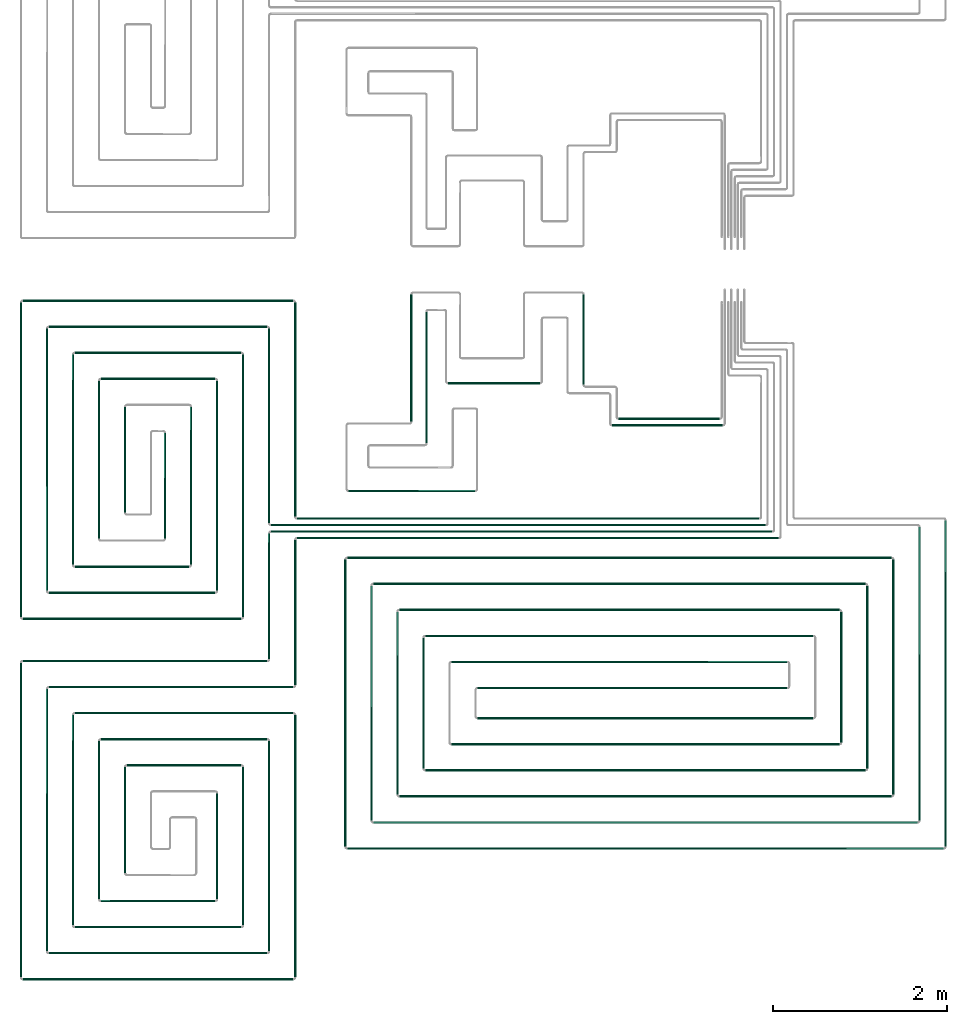
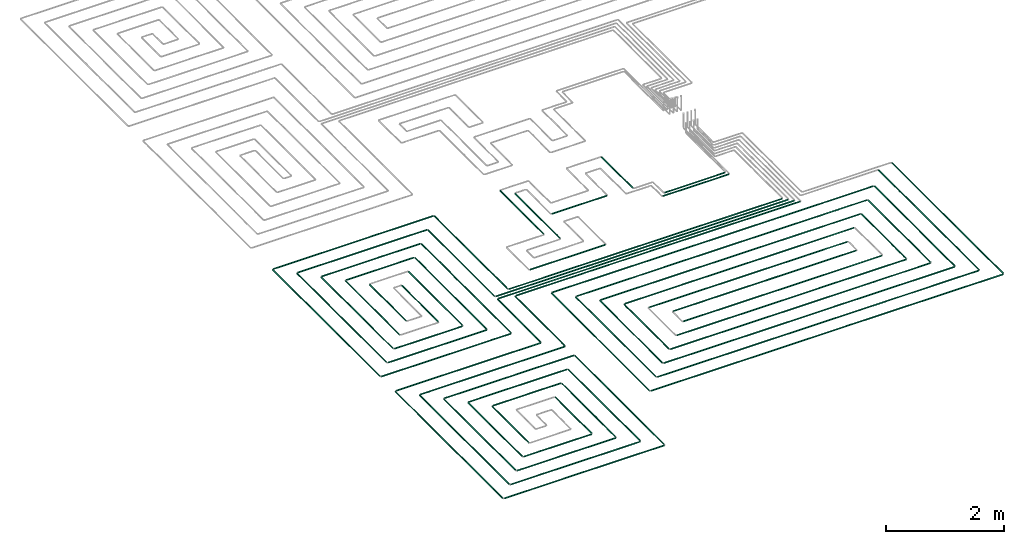
# One storey, part 1 of 12: 70 flow segments.
"""IFC2X3 building model written with IfcOpenShell, lengths in millimetres."""

from ifc_helpers import new_model, entity, si_unit, converted_unit, derived_unit, direction, frame, frame_2d, origin, origin_2d_with_axis, place, context, subcontext, project, spatial, circle, extrude, type_object, element, save


model = new_model("IFC2X3")

# Units and contexts
model_context = context("Model", 3, precision=0.01, world=origin(), true_north=direction((6.12303176911189e-17, 1.0)))
body_context = subcontext(model_context, "Body", "Model", "MODEL_VIEW")
ifc_project = project(units=[si_unit("LENGTHUNIT", "METRE", prefix="MILLI"), si_unit("AREAUNIT", "SQUARE_METRE"), si_unit("VOLUMEUNIT", "CUBIC_METRE"), converted_unit("PLANEANGLEUNIT", "DEGREE", entity("IfcRatioMeasure", 0.0174532925199433), si_unit("PLANEANGLEUNIT", "RADIAN"), dimensions=[0, 0, 0, 0, 0, 0, 0]), si_unit("MASSUNIT", "GRAM", prefix="KILO"), derived_unit("MASSDENSITYUNIT", [(si_unit("MASSUNIT", "GRAM", prefix="KILO"), 1), (si_unit("LENGTHUNIT", "METRE"), -3)]), si_unit("TIMEUNIT", "SECOND"), si_unit("FREQUENCYUNIT", "HERTZ"), si_unit("THERMODYNAMICTEMPERATUREUNIT", "DEGREE_CELSIUS"), derived_unit("THERMALTRANSMITTANCEUNIT", [(si_unit("MASSUNIT", "GRAM", prefix="KILO"), 1), (si_unit("THERMODYNAMICTEMPERATUREUNIT", "KELVIN"), -1), (si_unit("TIMEUNIT", "SECOND"), -3)]), derived_unit("VOLUMETRICFLOWRATEUNIT", [(si_unit("LENGTHUNIT", "METRE"), 3), (si_unit("TIMEUNIT", "SECOND"), -1)]), si_unit("ELECTRICCURRENTUNIT", "AMPERE"), si_unit("ELECTRICVOLTAGEUNIT", "VOLT"), si_unit("POWERUNIT", "WATT"), si_unit("FORCEUNIT", "NEWTON", prefix="KILO"), si_unit("ILLUMINANCEUNIT", "LUX"), si_unit("LUMINOUSFLUXUNIT", "LUMEN"), si_unit("LUMINOUSINTENSITYUNIT", "CANDELA"), derived_unit("USERDEFINED", [(si_unit("MASSUNIT", "GRAM", prefix="KILO"), -1), (si_unit("LENGTHUNIT", "METRE"), -2), (si_unit("TIMEUNIT", "SECOND"), 3), (si_unit("LUMINOUSFLUXUNIT", "LUMEN"), 1)]), derived_unit("LINEARVELOCITYUNIT", [(si_unit("LENGTHUNIT", "METRE"), 1), (si_unit("TIMEUNIT", "SECOND"), -1)]), si_unit("PRESSUREUNIT", "PASCAL"), derived_unit("USERDEFINED", [(si_unit("LENGTHUNIT", "METRE"), -2), (si_unit("MASSUNIT", "GRAM", prefix="KILO"), 1), (si_unit("TIMEUNIT", "SECOND"), -2)])], contexts=[model_context])

# Site, building, storey
site_placement = place(None, origin())
site = spatial("IfcSite", under=ifc_project, at=site_placement, CompositionType="ELEMENT")
building_placement = place(site_placement, origin())
building = spatial("IfcBuilding", under=site, at=building_placement, CompositionType="ELEMENT")
storey_placement = place(building_placement, frame((0.0, 0.0, 4000.0)))
storey = spatial("IfcBuildingStorey", under=building, at=storey_placement, Name="01 Level", CompositionType="ELEMENT", Elevation=4000.0)

# Flow segments
pipe_segment_type = type_object("IfcPipeSegmentType", PredefinedType="NOTDEFINED")
flow_segment_1_placement = place(storey_placement, frame((20884.4386293741, -71711.6450070283, -81.5952722359175)))
element("IfcFlowSegment", 1, at=flow_segment_1_placement, inside=storey, type_object=pipe_segment_type, context=body_context, shape_type="SweptSolid", body=[
    extrude(circle(Radius=10.0, at=frame_2d((-8.66293703438714e-12, 0.0), x_axis=(1.0, 0.0))), frame((0.0, 11.5952722359136, 11.5952722359158), z_axis=(1.0, 0.0, 0.0), x_axis=(0.0, 1.0, 0.0)), (0.0, 0.0, 1.0), 5324.24692007345),
])
flow_segment_2_placement = place(storey_placement, frame((20584.4386293741, -71786.6450070283, -81.5952722359161)))
element("IfcFlowSegment", 2, at=flow_segment_2_placement, inside=storey, type_object=pipe_segment_type, context=body_context, shape_type="SweptSolid", body=[
    extrude(circle(Radius=10.0, at=frame_2d((-8.66293703438714e-12, 0.0), x_axis=(1.0, 0.0))), frame((0.0, 11.5952722359223, 11.5952722359158), z_axis=(1.0, 0.0, 0.0), x_axis=(0.0, 1.0, 0.0)), (0.0, 0.0, 1.0), 5699.24692007345),
])
flow_segment_3_placement = place(storey_placement, frame((20584.4386293741, -71861.6450070283, -81.5952722359161)))
element("IfcFlowSegment", 3, at=flow_segment_3_placement, inside=storey, type_object=pipe_segment_type, context=body_context, shape_type="SweptSolid", body=[
    extrude(circle(Radius=10.0, at=frame_2d((-2.59888111031614e-11, 0.0), x_axis=(1.0, 0.0))), frame((0.0, 11.5952722359396, 11.5952722359158), z_axis=(1.0, 0.0, 0.0), x_axis=(0.0, 1.0, 0.0)), (0.0, 0.0, 1.0), 5774.24692007345),
])
flow_segment_4_placement = place(storey_placement, frame((20884.4386293741, -71936.6450070283, -81.5952722359161)))
element("IfcFlowSegment", 4, at=flow_segment_4_placement, inside=storey, type_object=pipe_segment_type, context=body_context, shape_type="SweptSolid", body=[
    extrude(circle(Radius=10.0, at=frame_2d((-1.73258740687743e-11, 0.0), x_axis=(1.0, 0.0))), frame((0.0, 11.595272235931, 11.5952722359158), z_axis=(1.0, 0.0, 0.0), x_axis=(0.0, 1.0, 0.0)), (0.0, 0.0, 1.0), 5549.24692007344),
])
flow_segment_5_placement = place(storey_placement, frame((20552.8433571382, -73321.2395851399, -81.5952722359189)))
element("IfcFlowSegment", 5, at=flow_segment_5_placement, inside=storey, type_object=pipe_segment_type, context=body_context, shape_type="SweptSolid", body=[
    extrude(circle(Radius=10.0, at=origin_2d_with_axis()), frame((11.595272235918, 0.0, 11.5952722359158), z_axis=(0.0, 1.0, 0.0), x_axis=(-1.0, 0.0, 0.0)), (0.0, 0.0, 1.0), 1451.18985034759),
])
flow_segment_6_placement = place(storey_placement, frame((20852.8433571382, -73621.2395851399, -81.5952722359189)))
element("IfcFlowSegment", 6, at=flow_segment_6_placement, inside=storey, type_object=pipe_segment_type, context=body_context, shape_type="SweptSolid", body=[
    extrude(circle(Radius=10.0, at=origin_2d_with_axis()), frame((11.5952722359223, 0.0, 11.5952722359158), z_axis=(0.0, 1.0, 0.0), x_axis=(-1.0, 0.0, 0.0)), (0.0, 0.0, 1.0), 1676.18985034759),
])
flow_segment_7_placement = place(storey_placement, frame((24586.730888343, -70562.9096240978, -81.5952722359261)))
element("IfcFlowSegment", 7, at=flow_segment_7_placement, inside=storey, type_object=pipe_segment_type, context=body_context, shape_type="SweptSolid", body=[
    extrude(circle(Radius=10.0, at=origin_2d_with_axis()), frame((0.0, 11.5952722359136, 11.5952722359158), z_axis=(1.0, 0.0, 0.0), x_axis=(0.0, -1.0, 0.0)), (0.0, 0.0, 1.0), 1169.30608362779),
])
flow_segment_8_placement = place(storey_placement, frame((20852.8433571382, -71680.0497347924, -81.5952722359189)))
element("IfcFlowSegment", 8, at=flow_segment_8_placement, inside=storey, type_object=pipe_segment_type, context=body_context, shape_type="SweptSolid", body=[
    extrude(circle(Radius=10.0, at=frame_2d((-2.16573425859679e-11, 0.0), x_axis=(1.0, 0.0))), frame((11.5952722359396, 0.0, 11.5952722359158), z_axis=(0.0, 1.0, 0.0), x_axis=(-1.0, 0.0, 0.0)), (0.0, 0.0, 1.0), 2468.81014965244),
])
flow_segment_9_placement = place(storey_placement, frame((20552.8433571382, -71755.0497347924, -81.5952722359189)))
element("IfcFlowSegment", 9, at=flow_segment_9_placement, inside=storey, type_object=pipe_segment_type, context=body_context, shape_type="SweptSolid", body=[
    extrude(circle(Radius=10.0, at=origin_2d_with_axis()), frame((11.5952722359223, 0.0, 11.5952722359158), z_axis=(0.0, 1.0, 0.0), x_axis=(1.0, 0.0, 0.0)), (0.0, 0.0, 1.0), 2243.81014965244),
])
flow_segment_10_placement = place(storey_placement, frame((17725.6253473195, -69202.8348573759, -81.5952722359189)))
element("IfcFlowSegment", 10, at=flow_segment_10_placement, inside=storey, type_object=pipe_segment_type, context=body_context, shape_type="SweptSolid", body=[
    extrude(circle(Radius=10.0, at=frame_2d((-1.73258740687743e-11, 0.0), x_axis=(1.0, 0.0))), frame((0.0, 11.595272235931, 11.5952722359158), z_axis=(1.0, 0.0, 0.0), x_axis=(0.0, 1.0, 0.0)), (0.0, 0.0, 1.0), 3118.81328205467),
])
flow_segment_11_placement = place(storey_placement, frame((18025.6253473195, -69502.8348573758, -81.5952722359189)))
element("IfcFlowSegment", 11, at=flow_segment_11_placement, inside=storey, type_object=pipe_segment_type, context=body_context, shape_type="SweptSolid", body=[
    extrude(circle(Radius=10.0, at=frame_2d((-1.73258740687743e-11, 0.0), x_axis=(1.0, 0.0))), frame((0.0, 11.595272235931, 11.5952722359158), z_axis=(1.0, 0.0, 0.0), x_axis=(0.0, 1.0, 0.0)), (0.0, 0.0, 1.0), 2518.81328205467),
])
flow_segment_12_placement = place(storey_placement, frame((17994.0300750835, -72534.5978364231, -81.5952722359202)))
element("IfcFlowSegment", 12, at=flow_segment_12_placement, inside=storey, type_object=pipe_segment_type, context=body_context, shape_type="SweptSolid", body=[
    extrude(circle(Radius=10.0, at=frame_2d((-2.38230768445646e-11, 0.0), x_axis=(1.0, 0.0))), frame((11.5952722359396, 0.0, 11.5952722359158), z_axis=(0.0, 1.0, 0.0), x_axis=(-1.0, 0.0, 0.0)), (0.0, 0.0, 1.0), 3023.35825128324),
])
flow_segment_13_placement = place(storey_placement, frame((17694.0300750835, -72834.5978364231, -81.5952722359202)))
element("IfcFlowSegment", 13, at=flow_segment_13_placement, inside=storey, type_object=pipe_segment_type, context=body_context, shape_type="SweptSolid", body=[
    extrude(circle(Radius=10.0, at=frame_2d((-2.16573425859679e-11, 0.0), x_axis=(1.0, 0.0))), frame((11.5952722359374, 0.0, 11.5952722359158), z_axis=(0.0, 1.0, 0.0), x_axis=(-1.0, 0.0, 0.0)), (0.0, 0.0, 1.0), 3623.35825128323),
])
flow_segment_14_placement = place(storey_placement, frame((18025.6253473194, -72566.1931086591, -81.5952722359189)))
element("IfcFlowSegment", 14, at=flow_segment_14_placement, inside=storey, type_object=pipe_segment_type, context=body_context, shape_type="SweptSolid", body=[
    extrude(circle(Radius=10.0, at=frame_2d((-8.66293703438714e-12, 0.0), x_axis=(1.0, 0.0))), frame((0.0, 11.5952722359223, 11.5952722359158), z_axis=(1.0, 0.0, 0.0), x_axis=(0.0, 1.0, 0.0)), (0.0, 0.0, 1.0), 1918.81328205468),
])
flow_segment_15_placement = place(storey_placement, frame((17725.6253473194, -72866.1931086591, -81.5952722359175)))
element("IfcFlowSegment", 15, at=flow_segment_15_placement, inside=storey, type_object=pipe_segment_type, context=body_context, shape_type="SweptSolid", body=[
    extrude(circle(Radius=10.0, at=frame_2d((-8.66293703438714e-12, 0.0), x_axis=(1.0, 0.0))), frame((0.0, 11.595272235931, 11.5952722359158), z_axis=(1.0, 0.0, 0.0), x_axis=(0.0, 1.0, 0.0)), (0.0, 0.0, 1.0), 2518.81328205467),
])
flow_segment_16_placement = place(storey_placement, frame((20252.8433571382, -72834.5978364231, -81.595272235922)))
element("IfcFlowSegment", 16, at=flow_segment_16_placement, inside=storey, type_object=pipe_segment_type, context=body_context, shape_type="SweptSolid", body=[
    extrude(circle(Radius=10.0, at=frame_2d((-2.59888111031614e-11, 0.0), x_axis=(1.0, 0.0))), frame((11.5952722359396, 0.0, 11.5952722359158), z_axis=(0.0, 1.0, 0.0), x_axis=(-1.0, 0.0, 0.0)), (0.0, 0.0, 1.0), 3023.35825128323),
])
flow_segment_17_placement = place(storey_placement, frame((19952.8433571382, -72534.5978364231, -81.5952722359189)))
element("IfcFlowSegment", 17, at=flow_segment_17_placement, inside=storey, type_object=pipe_segment_type, context=body_context, shape_type="SweptSolid", body=[
    extrude(circle(Radius=10.0, at=origin_2d_with_axis()), frame((11.5952722359223, 0.0, 11.5952722359158), z_axis=(0.0, 1.0, 0.0), x_axis=(1.0, 0.0, 0.0)), (0.0, 0.0, 1.0), 2423.35825128325),
])
flow_segment_18_placement = place(storey_placement, frame((18325.6253473194, -69802.8348573758, -81.595272235922)))
element("IfcFlowSegment", 18, at=flow_segment_18_placement, inside=storey, type_object=pipe_segment_type, context=body_context, shape_type="SweptSolid", body=[
    extrude(circle(Radius=10.0, at=origin_2d_with_axis()), frame((0.0, 11.5952722359396, 11.5952722359158), z_axis=(1.0, 0.0, 0.0), x_axis=(0.0, -1.0, 0.0)), (0.0, 0.0, 1.0), 1918.8132820547),
])
flow_segment_19_placement = place(storey_placement, frame((18625.6253473194, -70102.8348573758, -81.5952722359202)))
element("IfcFlowSegment", 19, at=flow_segment_19_placement, inside=storey, type_object=pipe_segment_type, context=body_context, shape_type="SweptSolid", body=[
    extrude(circle(Radius=10.0, at=frame_2d((-8.66293703438714e-12, 0.0), x_axis=(1.0, 0.0))), frame((0.0, 11.5952722359223, 11.5952722359158), z_axis=(1.0, 0.0, 0.0), x_axis=(0.0, 1.0, 0.0)), (0.0, 0.0, 1.0), 1318.8132820547),
])
flow_segment_20_placement = place(storey_placement, frame((18594.0300750835, -71934.5978364232, -81.595272235922)))
element("IfcFlowSegment", 20, at=flow_segment_20_placement, inside=storey, type_object=pipe_segment_type, context=body_context, shape_type="SweptSolid", body=[
    extrude(circle(Radius=10.0, at=frame_2d((-1.94916083273711e-11, 0.0), x_axis=(1.0, 0.0))), frame((11.5952722359353, 0.0, 11.5952722359158), z_axis=(0.0, 1.0, 0.0), x_axis=(-1.0, 0.0, 0.0)), (0.0, 0.0, 1.0), 1823.35825128327),
])
flow_segment_21_placement = place(storey_placement, frame((18294.0300750835, -72234.5978364231, -81.595272235922)))
element("IfcFlowSegment", 21, at=flow_segment_21_placement, inside=storey, type_object=pipe_segment_type, context=body_context, shape_type="SweptSolid", body=[
    extrude(circle(Radius=10.0, at=frame_2d((-1.94916083273711e-11, 0.0), x_axis=(1.0, 0.0))), frame((11.5952722359353, 0.0, 11.5952722359158), z_axis=(0.0, 1.0, 0.0), x_axis=(-1.0, 0.0, 0.0)), (0.0, 0.0, 1.0), 2423.35825128326),
])
flow_segment_22_placement = place(storey_placement, frame((18325.6253473194, -72266.1931086591, -81.595272235922)))
element("IfcFlowSegment", 22, at=flow_segment_22_placement, inside=storey, type_object=pipe_segment_type, context=body_context, shape_type="SweptSolid", body=[
    extrude(circle(Radius=10.0, at=frame_2d((-8.66293703438714e-12, 0.0), x_axis=(1.0, 0.0))), frame((0.0, 11.5952722359223, 11.5952722359158), z_axis=(1.0, 0.0, 0.0), x_axis=(0.0, 1.0, 0.0)), (0.0, 0.0, 1.0), 1318.81328205471),
])
flow_segment_23_placement = place(storey_placement, frame((19652.8433571382, -72234.5978364232, -81.5952722359234)))
element("IfcFlowSegment", 23, at=flow_segment_23_placement, inside=storey, type_object=pipe_segment_type, context=body_context, shape_type="SweptSolid", body=[
    extrude(circle(Radius=10.0, at=frame_2d((-1.29944055515807e-11, 0.0), x_axis=(1.0, 0.0))), frame((11.595272235931, 0.0, 11.5952722359158), z_axis=(0.0, 1.0, 0.0), x_axis=(-1.0, 0.0, 0.0)), (0.0, 0.0, 1.0), 1823.35825128327),
])
flow_segment_24_placement = place(storey_placement, frame((19352.8433571382, -71934.5978364232, -81.5952722359229)))
element("IfcFlowSegment", 24, at=flow_segment_24_placement, inside=storey, type_object=pipe_segment_type, context=body_context, shape_type="SweptSolid", body=[
    extrude(circle(Radius=10.0, at=frame_2d((-8.66293703438714e-12, 0.0), x_axis=(1.0, 0.0))), frame((11.5952722359245, 0.0, 11.5952722359158), z_axis=(0.0, 1.0, 0.0), x_axis=(-1.0, 0.0, 0.0)), (0.0, 0.0, 1.0), 1223.35825128328),
])
flow_segment_25_placement = place(storey_placement, frame((18894.0300750835, -71634.5978364232, -81.5952722359239)))
element("IfcFlowSegment", 25, at=flow_segment_25_placement, inside=storey, type_object=pipe_segment_type, context=body_context, shape_type="SweptSolid", body=[
    extrude(circle(Radius=10.0, at=frame_2d((-1.51601398101775e-11, 0.0), x_axis=(1.0, 0.0))), frame((11.595272235931, 0.0, 11.5952722359158), z_axis=(0.0, 1.0, 0.0), x_axis=(-1.0, 0.0, 0.0)), (0.0, 0.0, 1.0), 1223.35825128332),
])
flow_segment_26_placement = place(storey_placement, frame((20852.8433571382, -76984.5978364232, -81.5952722359198)))
element("IfcFlowSegment", 26, at=flow_segment_26_placement, inside=storey, type_object=pipe_segment_type, context=body_context, shape_type="SweptSolid", body=[
    extrude(circle(Radius=10.0, at=frame_2d((-2.59888111031614e-11, 0.0), x_axis=(1.0, 0.0))), frame((11.5952722359353, 0.0, 11.5952722359158), z_axis=(0.0, 1.0, 0.0), x_axis=(-1.0, 0.0, 0.0)), (0.0, 0.0, 1.0), 3023.35825128325),
])
flow_segment_27_placement = place(storey_placement, frame((20552.8433571382, -76684.5978364232, -81.5952722359179)))
element("IfcFlowSegment", 27, at=flow_segment_27_placement, inside=storey, type_object=pipe_segment_type, context=body_context, shape_type="SweptSolid", body=[
    extrude(circle(Radius=10.0, at=origin_2d_with_axis()), frame((11.595272235918, 0.0, 11.5952722359158), z_axis=(0.0, 1.0, 0.0), x_axis=(1.0, 0.0, 0.0)), (0.0, 0.0, 1.0), 2423.35825128326),
])
flow_segment_28_placement = place(storey_placement, frame((17994.0300750835, -76684.5978364232, -81.595272235922)))
element("IfcFlowSegment", 28, at=flow_segment_28_placement, inside=storey, type_object=pipe_segment_type, context=body_context, shape_type="SweptSolid", body=[
    extrude(circle(Radius=10.0, at=frame_2d((-2.81545453617582e-11, 0.0), x_axis=(1.0, 0.0))), frame((11.5952722359439, 0.0, 11.5952722359158), z_axis=(0.0, 1.0, 0.0), x_axis=(-1.0, 0.0, 0.0)), (0.0, 0.0, 1.0), 3023.35825128327),
])
flow_segment_29_placement = place(storey_placement, frame((17694.0300750835, -76984.5978364231, -81.595272235922)))
element("IfcFlowSegment", 29, at=flow_segment_29_placement, inside=storey, type_object=pipe_segment_type, context=body_context, shape_type="SweptSolid", body=[
    extrude(circle(Radius=10.0, at=frame_2d((-2.81545453617582e-11, 0.0), x_axis=(1.0, 0.0))), frame((11.5952722359418, 0.0, 11.5952722359158), z_axis=(0.0, 1.0, 0.0), x_axis=(-1.0, 0.0, 0.0)), (0.0, 0.0, 1.0), 3623.35825128325),
])
flow_segment_30_placement = place(storey_placement, frame((20252.8433571382, -76384.5978364232, -81.5952722359229)))
element("IfcFlowSegment", 30, at=flow_segment_30_placement, inside=storey, type_object=pipe_segment_type, context=body_context, shape_type="SweptSolid", body=[
    extrude(circle(Radius=10.0, at=frame_2d((-2.16573425859679e-11, 0.0), x_axis=(1.0, 0.0))), frame((11.5952722359396, 0.0, 11.5952722359158), z_axis=(0.0, 1.0, 0.0), x_axis=(-1.0, 0.0, 0.0)), (0.0, 0.0, 1.0), 1823.35825128329),
])
flow_segment_31_placement = place(storey_placement, frame((19952.8433571382, -76084.5978364232, -81.5952722359202)))
element("IfcFlowSegment", 31, at=flow_segment_31_placement, inside=storey, type_object=pipe_segment_type, context=body_context, shape_type="SweptSolid", body=[
    extrude(circle(Radius=10.0, at=origin_2d_with_axis()), frame((11.595272235918, 0.0, 11.5952722359158), z_axis=(0.0, 1.0, 0.0), x_axis=(1.0, 0.0, 0.0)), (0.0, 0.0, 1.0), 1223.35825128325),
])
flow_segment_32_placement = place(storey_placement, frame((18594.0300750835, -76084.5978364232, -81.5952722359284)))
element("IfcFlowSegment", 32, at=flow_segment_32_placement, inside=storey, type_object=pipe_segment_type, context=body_context, shape_type="SweptSolid", body=[
    extrude(circle(Radius=10.0, at=origin_2d_with_axis()), frame((11.5952722359158, 0.0, 11.5952722359158), z_axis=(0.0, 1.0, 0.0), x_axis=(1.0, 0.0, 0.0)), (0.0, 0.0, 1.0), 1823.35825128331),
])
flow_segment_33_placement = place(storey_placement, frame((18294.0300750835, -76384.5978364232, -81.5952722359261)))
element("IfcFlowSegment", 33, at=flow_segment_33_placement, inside=storey, type_object=pipe_segment_type, context=body_context, shape_type="SweptSolid", body=[
    extrude(circle(Radius=10.0, at=origin_2d_with_axis()), frame((11.5952722359158, 0.0, 11.5952722359158), z_axis=(0.0, 1.0, 0.0), x_axis=(1.0, 0.0, 0.0)), (0.0, 0.0, 1.0), 2423.35825128329),
])
flow_segment_34_placement = place(storey_placement, frame((18894.0300750835, -75784.5978364232, -81.5952722359257)))
element("IfcFlowSegment", 34, at=flow_segment_34_placement, inside=storey, type_object=pipe_segment_type, context=body_context, shape_type="SweptSolid", body=[
    extrude(circle(Radius=10.0, at=frame_2d((-2.16573425859679e-11, 0.0), x_axis=(1.0, 0.0))), frame((11.5952722359353, 0.0, 11.5952722359158), z_axis=(0.0, 1.0, 0.0), x_axis=(-1.0, 0.0, 0.0)), (0.0, 0.0, 1.0), 1223.35825128335),
])
for number, where in (
    (35, (17725.6253473195, -73352.8348573759, -81.5952722359175)),
    (36, (18025.6253473194, -73652.8348573759, -81.595272235917)),
):
    element("IfcFlowSegment", number, at=place(storey_placement, frame(where)), inside=storey, type_object=pipe_segment_type, context=body_context, shape_type="SweptSolid", body=[
        extrude(circle(Radius=10.0, at=frame_2d((-3.46517481375486e-11, 0.0), x_axis=(1.0, 0.0))), frame((0.0, 11.5952722359483, 11.5952722359158), z_axis=(1.0, 0.0, 0.0), x_axis=(0.0, 1.0, 0.0)), (0.0, 0.0, 1.0), 2818.81328205464),
    ])
flow_segment_35_placement = place(storey_placement, frame((18025.6253473194, -76716.1931086591, -81.5952722359179)))
element("IfcFlowSegment", 37, at=flow_segment_35_placement, inside=storey, type_object=pipe_segment_type, context=body_context, shape_type="SweptSolid", body=[
    extrude(circle(Radius=10.0, at=frame_2d((-8.66293703438714e-12, 0.0), x_axis=(1.0, 0.0))), frame((0.0, 11.5952722359136, 11.5952722359158), z_axis=(1.0, 0.0, 0.0), x_axis=(0.0, 1.0, 0.0)), (0.0, 0.0, 1.0), 2518.8132820547),
])
flow_segment_36_placement = place(storey_placement, frame((17725.6253473194, -77016.1931086591, -81.595272235917)))
element("IfcFlowSegment", 38, at=flow_segment_36_placement, inside=storey, type_object=pipe_segment_type, context=body_context, shape_type="SweptSolid", body=[
    extrude(circle(Radius=10.0, at=frame_2d((-8.66293703438714e-12, 0.0), x_axis=(1.0, 0.0))), frame((0.0, 11.595272235931, 11.5952722359158), z_axis=(1.0, 0.0, 0.0), x_axis=(0.0, 1.0, 0.0)), (0.0, 0.0, 1.0), 3118.81328205468),
])
flow_segment_37_placement = place(storey_placement, frame((18325.6253473194, -73952.8348573758, -81.5952722359198)))
element("IfcFlowSegment", 39, at=flow_segment_37_placement, inside=storey, type_object=pipe_segment_type, context=body_context, shape_type="SweptSolid", body=[
    extrude(circle(Radius=10.0, at=frame_2d((-1.73258740687743e-11, 0.0), x_axis=(1.0, 0.0))), frame((0.0, 11.595272235931, 11.5952722359158), z_axis=(1.0, 0.0, 0.0), x_axis=(0.0, 1.0, 0.0)), (0.0, 0.0, 1.0), 2518.8132820547),
])
flow_segment_38_placement = place(storey_placement, frame((18625.6253473194, -74252.8348573758, -81.5952722359202)))
element("IfcFlowSegment", 40, at=flow_segment_38_placement, inside=storey, type_object=pipe_segment_type, context=body_context, shape_type="SweptSolid", body=[
    extrude(circle(Radius=10.0, at=frame_2d((-1.73258740687743e-11, 0.0), x_axis=(1.0, 0.0))), frame((0.0, 11.595272235931, 11.5952722359158), z_axis=(1.0, 0.0, 0.0), x_axis=(0.0, 1.0, 0.0)), (0.0, 0.0, 1.0), 1918.8132820547),
])
flow_segment_39_placement = place(storey_placement, frame((18625.6253473194, -76116.1931086591, -81.5952722359202)))
element("IfcFlowSegment", 41, at=flow_segment_39_placement, inside=storey, type_object=pipe_segment_type, context=body_context, shape_type="SweptSolid", body=[
    extrude(circle(Radius=10.0, at=origin_2d_with_axis()), frame((0.0, 11.5952722359136, 11.5952722359158), z_axis=(1.0, 0.0, 0.0), x_axis=(0.0, 1.0, 0.0)), (0.0, 0.0, 1.0), 1318.81328205473),
])
flow_segment_40_placement = place(storey_placement, frame((18325.6253473194, -76416.1931086591, -81.5952722359198)))
element("IfcFlowSegment", 42, at=flow_segment_40_placement, inside=storey, type_object=pipe_segment_type, context=body_context, shape_type="SweptSolid", body=[
    extrude(circle(Radius=10.0, at=frame_2d((-8.66293703438714e-12, 0.0), x_axis=(1.0, 0.0))), frame((0.0, 11.5952722359223, 11.5952722359158), z_axis=(1.0, 0.0, 0.0), x_axis=(0.0, 1.0, 0.0)), (0.0, 0.0, 1.0), 1918.81328205471),
])
flow_segment_41_placement = place(storey_placement, frame((18925.6253473194, -74552.8348573758, -81.5952722359229)))
element("IfcFlowSegment", 43, at=flow_segment_41_placement, inside=storey, type_object=pipe_segment_type, context=body_context, shape_type="SweptSolid", body=[
    extrude(circle(Radius=10.0, at=frame_2d((-8.66293703438714e-12, 0.0), x_axis=(1.0, 0.0))), frame((0.0, 11.5952722359223, 11.5952722359158), z_axis=(1.0, 0.0, 0.0), x_axis=(0.0, 1.0, 0.0)), (0.0, 0.0, 1.0), 1318.81328205473),
])
flow_segment_42_placement = place(storey_placement, frame((28341.5018091839, -75479.8436457932, -81.5952722359161)))
element("IfcFlowSegment", 44, at=flow_segment_42_placement, inside=storey, type_object=pipe_segment_type, context=body_context, shape_type="SweptSolid", body=[
    extrude(circle(Radius=10.0, at=origin_2d_with_axis()), frame((11.595272235918, 0.0, 11.5952722359158), z_axis=(0.0, 1.0, 0.0), x_axis=(1.0, 0.0, 0.0)), (0.0, 0.0, 1.0), 3759.79391100087),
])
flow_segment_43_placement = place(storey_placement, frame((28041.5018091839, -75179.8436457933, -81.5952722359193)))
element("IfcFlowSegment", 45, at=flow_segment_43_placement, inside=storey, type_object=pipe_segment_type, context=body_context, shape_type="SweptSolid", body=[
    extrude(circle(Radius=10.0, at=frame_2d((-2.59888111031614e-11, 0.0), x_axis=(1.0, 0.0))), frame((11.5952722359526, 0.0, 11.5952722359158), z_axis=(0.0, 1.0, 0.0), x_axis=(-1.0, 0.0, 0.0)), (0.0, 0.0, 1.0), 3384.79391100087),
])
flow_segment_44_placement = place(storey_placement, frame((27741.5018091839, -74879.8436457933, -81.5952722359175)))
element("IfcFlowSegment", 46, at=flow_segment_44_placement, inside=storey, type_object=pipe_segment_type, context=body_context, shape_type="SweptSolid", body=[
    extrude(circle(Radius=10.0, at=origin_2d_with_axis()), frame((11.5952722359223, 0.0, 11.5952722359158), z_axis=(0.0, 1.0, 0.0), x_axis=(1.0, 0.0, 0.0)), (0.0, 0.0, 1.0), 2707.85893213088),
])
flow_segment_45_placement = place(storey_placement, frame((27441.5018091839, -74579.8436457933, -81.5952722359166)))
element("IfcFlowSegment", 47, at=flow_segment_45_placement, inside=storey, type_object=pipe_segment_type, context=body_context, shape_type="SweptSolid", body=[
    extrude(circle(Radius=10.0, at=frame_2d((-2.16573425859679e-11, 0.0), x_axis=(1.0, 0.0))), frame((11.5952722359396, 0.0, 11.5952722359158), z_axis=(0.0, 1.0, 0.0), x_axis=(-1.0, 0.0, 0.0)), (0.0, 0.0, 1.0), 2107.85893213088),
])
flow_segment_46_placement = place(storey_placement, frame((21730.6562350407, -75179.8436457932, -81.5952722359266)))
element("IfcFlowSegment", 48, at=flow_segment_46_placement, inside=storey, type_object=pipe_segment_type, context=body_context, shape_type="SweptSolid", body=[
    extrude(circle(Radius=10.0, at=frame_2d((-3.46517481375486e-11, 0.0), x_axis=(1.0, 0.0))), frame((11.5952722359526, 0.0, 11.5952722359158), z_axis=(0.0, 1.0, 0.0), x_axis=(-1.0, 0.0, 0.0)), (0.0, 0.0, 1.0), 2707.85893213097),
])
flow_segment_47_placement = place(storey_placement, frame((21430.6562350407, -75479.8436457932, -81.595272235928)))
element("IfcFlowSegment", 49, at=flow_segment_47_placement, inside=storey, type_object=pipe_segment_type, context=body_context, shape_type="SweptSolid", body=[
    extrude(circle(Radius=10.0, at=frame_2d((-2.59888111031614e-11, 0.0), x_axis=(1.0, 0.0))), frame((11.5952722359483, 0.0, 11.5952722359158), z_axis=(0.0, 1.0, 0.0), x_axis=(-1.0, 0.0, 0.0)), (0.0, 0.0, 1.0), 3307.85893213096),
])
flow_segment_48_placement = place(storey_placement, frame((22330.6562350407, -74579.8436457932, -81.595272235932)))
element("IfcFlowSegment", 50, at=flow_segment_48_placement, inside=storey, type_object=pipe_segment_type, context=body_context, shape_type="SweptSolid", body=[
    extrude(circle(Radius=10.0, at=frame_2d((-2.59888111031614e-11, 0.0), x_axis=(1.0, 0.0))), frame((11.5952722359353, 0.0, 11.5952722359158), z_axis=(0.0, 1.0, 0.0), x_axis=(-1.0, 0.0, 0.0)), (0.0, 0.0, 1.0), 1507.858932131),
])
flow_segment_49_placement = place(storey_placement, frame((22030.6562350407, -74879.8436457932, -81.595272235933)))
element("IfcFlowSegment", 51, at=flow_segment_49_placement, inside=storey, type_object=pipe_segment_type, context=body_context, shape_type="SweptSolid", body=[
    extrude(circle(Radius=10.0, at=frame_2d((-2.16573425859679e-11, 0.0), x_axis=(1.0, 0.0))), frame((11.5952722359396, 0.0, 11.5952722359158), z_axis=(0.0, 1.0, 0.0), x_axis=(-1.0, 0.0, 0.0)), (0.0, 0.0, 1.0), 2107.85893213099),
])
flow_segment_50_placement = place(storey_placement, frame((21762.2515072766, -75211.4389180292, -81.5952722359275)))
element("IfcFlowSegment", 52, at=flow_segment_50_placement, inside=storey, type_object=pipe_segment_type, context=body_context, shape_type="SweptSolid", body=[
    extrude(circle(Radius=10.0, at=origin_2d_with_axis()), frame((0.0, 11.5952722359483, 11.5952722359158), z_axis=(1.0, 0.0, 0.0), x_axis=(0.0, -1.0, 0.0)), (0.0, 0.0, 1.0), 6270.84557414324),
])
flow_segment_51_placement = place(storey_placement, frame((21462.2515072766, -75511.4389180292, -81.5952722359161)))
element("IfcFlowSegment", 53, at=flow_segment_51_placement, inside=storey, type_object=pipe_segment_type, context=body_context, shape_type="SweptSolid", body=[
    extrude(circle(Radius=10.0, at=frame_2d((-2.59888111031614e-11, 0.0), x_axis=(1.0, 0.0))), frame((0.0, 11.5952722359396, 11.5952722359158), z_axis=(1.0, 0.0, 0.0), x_axis=(0.0, 1.0, 0.0)), (0.0, 0.0, 1.0), 6870.84557414322),
])
flow_segment_52_placement = place(storey_placement, frame((22362.2515072766, -74611.4389180292, -81.5952722359229)))
element("IfcFlowSegment", 54, at=flow_segment_52_placement, inside=storey, type_object=pipe_segment_type, context=body_context, shape_type="SweptSolid", body=[
    extrude(circle(Radius=10.0, at=frame_2d((-8.66293703438714e-12, 0.0), x_axis=(1.0, 0.0))), frame((0.0, 11.5952722359223, 11.5952722359158), z_axis=(1.0, 0.0, 0.0), x_axis=(0.0, 1.0, 0.0)), (0.0, 0.0, 1.0), 5070.84557414327),
])
flow_segment_53_placement = place(storey_placement, frame((22062.2515072766, -74911.4389180292, -81.5952722359293)))
element("IfcFlowSegment", 55, at=flow_segment_53_placement, inside=storey, type_object=pipe_segment_type, context=body_context, shape_type="SweptSolid", body=[
    extrude(circle(Radius=10.0, at=origin_2d_with_axis()), frame((0.0, 11.5952722359656, 11.5952722359158), z_axis=(1.0, 0.0, 0.0), x_axis=(0.0, -1.0, 0.0)), (0.0, 0.0, 1.0), 5670.84557414326),
])
flow_segment_54_placement = place(storey_placement, frame((21462.2515072766, -72163.5799858983, -81.5952722359266)))
element("IfcFlowSegment", 56, at=flow_segment_54_placement, inside=storey, type_object=pipe_segment_type, context=body_context, shape_type="SweptSolid", body=[
    extrude(circle(Radius=10.0, at=frame_2d((-7.79664333094843e-11, 0.0), x_axis=(1.0, 0.0))), frame((0.0, 11.5952722359916, 11.5952722359158), z_axis=(1.0, 0.0, 0.0), x_axis=(0.0, 1.0, 0.0)), (0.0, 0.0, 1.0), 6270.84557414324),
])
flow_segment_55_placement = place(storey_placement, frame((21762.2515072766, -72463.5799858983, -81.5952722359166)))
element("IfcFlowSegment", 57, at=flow_segment_55_placement, inside=storey, type_object=pipe_segment_type, context=body_context, shape_type="SweptSolid", body=[
    extrude(circle(Radius=10.0, at=frame_2d((-6.064055924071e-11, 0.0), x_axis=(1.0, 0.0))), frame((0.0, 11.5952722359829, 11.5952722359158), z_axis=(1.0, 0.0, 0.0), x_axis=(0.0, 1.0, 0.0)), (0.0, 0.0, 1.0), 5670.84557414323),
])
flow_segment_56_placement = place(storey_placement, frame((22062.2515072766, -72763.5799858982, -81.5952722359248)))
element("IfcFlowSegment", 58, at=flow_segment_56_placement, inside=storey, type_object=pipe_segment_type, context=body_context, shape_type="SweptSolid", body=[
    extrude(circle(Radius=10.0, at=frame_2d((-5.19776222063229e-11, 0.0), x_axis=(1.0, 0.0))), frame((0.0, 11.5952722359656, 11.5952722359158), z_axis=(1.0, 0.0, 0.0), x_axis=(0.0, 1.0, 0.0)), (0.0, 0.0, 1.0), 5070.84557414326),
])
flow_segment_57_placement = place(storey_placement, frame((22362.2515072766, -73063.5799858982, -81.5952722359198)))
element("IfcFlowSegment", 59, at=flow_segment_57_placement, inside=storey, type_object=pipe_segment_type, context=body_context, shape_type="SweptSolid", body=[
    extrude(circle(Radius=10.0, at=frame_2d((-4.33146851719357e-11, 0.0), x_axis=(1.0, 0.0))), frame((0.0, 11.5952722359569, 11.5952722359158), z_axis=(1.0, 0.0, 0.0), x_axis=(0.0, 1.0, 0.0)), (0.0, 0.0, 1.0), 4470.84557414325),
])
flow_segment_58_placement = place(storey_placement, frame((27141.5018091839, -74279.8436457933, -81.5952722359207)))
element("IfcFlowSegment", 60, at=flow_segment_58_placement, inside=storey, type_object=pipe_segment_type, context=body_context, shape_type="SweptSolid", body=[
    extrude(circle(Radius=10.0, at=origin_2d_with_axis()), frame((11.595272235918, 0.0, 11.5952722359158), z_axis=(0.0, 1.0, 0.0), x_axis=(1.0, 0.0, 0.0)), (0.0, 0.0, 1.0), 1507.85893213094),
])
flow_segment_59_placement = place(storey_placement, frame((22962.2515072765, -74011.4389180292, -81.5952722359393)))
element("IfcFlowSegment", 61, at=flow_segment_59_placement, inside=storey, type_object=pipe_segment_type, context=body_context, shape_type="SweptSolid", body=[
    extrude(circle(Radius=10.0, at=origin_2d_with_axis()), frame((0.0, 11.595272235931, 11.5952722359158), z_axis=(1.0, 0.0, 0.0), x_axis=(0.0, -1.0, 0.0)), (0.0, 0.0, 1.0), 3870.84557414329),
])
flow_segment_60_placement = place(storey_placement, frame((22662.2515072766, -74311.4389180292, -81.595272235933)))
element("IfcFlowSegment", 62, at=flow_segment_60_placement, inside=storey, type_object=pipe_segment_type, context=body_context, shape_type="SweptSolid", body=[
    extrude(circle(Radius=10.0, at=origin_2d_with_axis()), frame((0.0, 11.5952722359483, 11.5952722359158), z_axis=(1.0, 0.0, 0.0), x_axis=(0.0, -1.0, 0.0)), (0.0, 0.0, 1.0), 4470.84557414328),
])
flow_segment_61_placement = place(storey_placement, frame((22662.2515072766, -73363.5799858982, -81.5952722359266)))
element("IfcFlowSegment", 63, at=flow_segment_61_placement, inside=storey, type_object=pipe_segment_type, context=body_context, shape_type="SweptSolid", body=[
    extrude(circle(Radius=10.0, at=frame_2d((-4.33146851719357e-11, 0.0), x_axis=(1.0, 0.0))), frame((0.0, 11.5952722359569, 11.5952722359158), z_axis=(1.0, 0.0, 0.0), x_axis=(0.0, 1.0, 0.0)), (0.0, 0.0, 1.0), 3870.84557414328),
])
flow_segment_62_placement = place(storey_placement, frame((22962.2515072766, -73663.5799858983, -81.5952722359275)))
element("IfcFlowSegment", 64, at=flow_segment_62_placement, inside=storey, type_object=pipe_segment_type, context=body_context, shape_type="SweptSolid", body=[
    extrude(circle(Radius=10.0, at=frame_2d((-5.19776222063229e-11, 0.0), x_axis=(1.0, 0.0))), frame((0.0, 11.5952722359656, 11.5952722359158), z_axis=(1.0, 0.0, 0.0), x_axis=(0.0, 1.0, 0.0)), (0.0, 0.0, 1.0), 3570.8455741433),
])
flow_segment_63_placement = place(storey_placement, frame((24174.4137837032, -70162.4616421941, -81.5952722359302)))
element("IfcFlowSegment", 65, at=flow_segment_63_placement, inside=storey, type_object=pipe_segment_type, context=body_context, shape_type="SweptSolid", body=[
    extrude(circle(Radius=10.0, at=frame_2d((-3.46517481375486e-11, 0.0), x_axis=(1.0, 0.0))), frame((11.5952722359483, 0.0, 11.5952722359158), z_axis=(0.0, 1.0, 0.0), x_axis=(-1.0, 0.0, 0.0)), (0.0, 0.0, 1.0), 1044.42186360162),
])
flow_segment_64_placement = place(storey_placement, frame((21476.9829033853, -71393.9202306541, -81.5952722359293)))
element("IfcFlowSegment", 66, at=flow_segment_64_placement, inside=storey, type_object=pipe_segment_type, context=body_context, shape_type="SweptSolid", body=[
    extrude(circle(Radius=10.0, at=origin_2d_with_axis()), frame((0.0, 11.5952722359136, 11.5952722359158), z_axis=(1.0, 0.0, 0.0), x_axis=(0.0, 1.0, 0.0)), (0.0, 0.0, 1.0), 1461.77751147482),
])
flow_segment_65_placement = place(storey_placement, frame((22190.153709968, -70586.2395851399, -81.5952722359302)))
element("IfcFlowSegment", 67, at=flow_segment_65_placement, inside=storey, type_object=pipe_segment_type, context=body_context, shape_type="SweptSolid", body=[
    extrude(circle(Radius=10.0, at=frame_2d((-1.29944055515807e-11, 0.0), x_axis=(1.0, 0.0))), frame((11.595272235931, 0.0, 11.5952722359158), z_axis=(0.0, 1.0, 0.0), x_axis=(-1.0, 0.0, 0.0)), (0.0, 0.0, 1.0), 1468.19980654745),
])
flow_segment_66_placement = place(storey_placement, frame((22365.153709968, -70836.2395851399, -81.5952722359225)))
element("IfcFlowSegment", 68, at=flow_segment_66_placement, inside=storey, type_object=pipe_segment_type, context=body_context, shape_type="SweptSolid", body=[
    extrude(circle(Radius=10.0, at=frame_2d((-1.29944055515807e-11, 0.0), x_axis=(1.0, 0.0))), frame((11.595272235931, 0.0, 11.5952722359158), z_axis=(0.0, 1.0, 0.0), x_axis=(-1.0, 0.0, 0.0)), (0.0, 0.0, 1.0), 1518.19980654744),
])
flow_segment_67_placement = place(storey_placement, frame((24511.730888343, -70637.9096240978, -81.5952722359257)))
element("IfcFlowSegment", 69, at=flow_segment_67_placement, inside=storey, type_object=pipe_segment_type, context=body_context, shape_type="SweptSolid", body=[
    extrude(circle(Radius=10.0, at=origin_2d_with_axis()), frame((0.0, 11.5952722359136, 11.5952722359158), z_axis=(1.0, 0.0, 0.0), x_axis=(0.0, -1.0, 0.0)), (0.0, 0.0, 1.0), 1279.3060836278),
])
flow_segment_68_placement = place(storey_placement, frame((22622.1485075651, -70152.8348573759, -81.5952722359339)))
element("IfcFlowSegment", 70, at=flow_segment_68_placement, inside=storey, type_object=pipe_segment_type, context=body_context, shape_type="SweptSolid", body=[
    extrude(circle(Radius=10.0, at=frame_2d((-1.73258740687743e-11, 0.0), x_axis=(1.0, 0.0))), frame((0.0, 11.595272235931, 11.5952722359158), z_axis=(1.0, 0.0, 0.0), x_axis=(0.0, 1.0, 0.0)), (0.0, 0.0, 1.0), 1062.80764523384),
])

save(model, "model.ifc")
